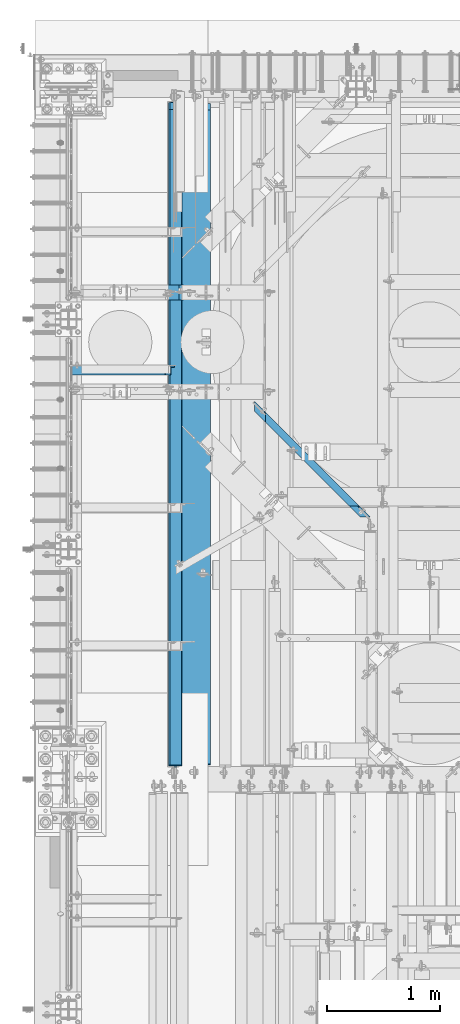
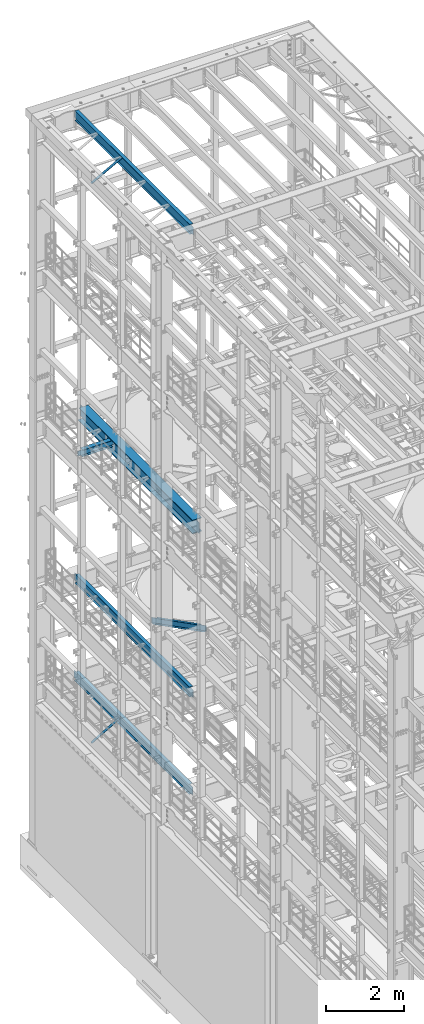
# One storey, part 1050 of 1876: 6 beams, 2 members, 8 elements without a shape of their own.
"""IFC2X3 building model written with IfcOpenShell, lengths in millimetres."""

from ifc_helpers import new_model, si_unit, frame, origin_with_axes, place, context, subcontext, project, spatial, faceted_brep, material, type_object, element, aggregate, save


model = new_model("IFC2X3")

# Units and contexts
model_context = context("Model", 3, precision=1e-05, world=origin_with_axes())
body_context = subcontext(model_context, "Body", "Model", "MODEL_VIEW")
ifc_project = project(units=[si_unit("LENGTHUNIT", "METRE", prefix="MILLI"), si_unit("AREAUNIT", "SQUARE_METRE"), si_unit("VOLUMEUNIT", "CUBIC_METRE"), si_unit("MASSUNIT", "GRAM", prefix="KILO"), si_unit("TIMEUNIT", "SECOND"), si_unit("PLANEANGLEUNIT", "RADIAN"), si_unit("SOLIDANGLEUNIT", "STERADIAN"), si_unit("THERMODYNAMICTEMPERATUREUNIT", "DEGREE_CELSIUS"), si_unit("LUMINOUSINTENSITYUNIT", "LUMEN")], contexts=[model_context])

# Site, building, storey
site_placement = place(None, origin_with_axes())
site = spatial("IfcSite", under=ifc_project, at=site_placement, CompositionType="ELEMENT")
building_placement = place(site_placement, origin_with_axes())
building = spatial("IfcBuilding", under=site, at=building_placement, Name="Undefined", CompositionType="ELEMENT")
storey_placement = place(building_placement, origin_with_axes())
storey = spatial("IfcBuildingStorey", under=building, at=storey_placement, Name="Undefined", CompositionType="ELEMENT", Elevation=0.0)

# Assembly, member
assembly_1_placement = place(storey_placement, origin_with_axes())
assembly_1 = element("IfcElementAssembly", 1, at=assembly_1_placement, inside=storey, AssemblyPlace="NOTDEFINED", PredefinedType="RIGID_FRAME")
ifc_material_1 = material(Name="STEEL/A36")
member_type = type_object("IfcMemberType", Name="L3X3X3/8", PredefinedType="NOTDEFINED")
member_1_placement = place(assembly_1_placement, frame((19.2391985516099, 11229.975, 4577.2144175513), z_axis=(0.0, -1.0, 0.0), x_axis=(0.863139327949449, 0.0, 0.50496584097043)))
member_1 = element("IfcMember", 2, at=member_1_placement, type_object=member_type, material=ifc_material_1, ObjectType="L3X3X3/8", context=body_context, shape_type="Brep", body=[
    faceted_brep([(22.9902048797903, -38.0999999999885, -38.1000000000004), (22.9902048797903, -38.0999999999885, -28.5750000000007), (22.9902048798026, 28.5750000000021, -28.5750000000007), (22.9902048798026, 28.5750000000021, 38.1000000000004), (22.990204879804, 38.0999999999999, 38.1000000000004), (22.990204879804, 38.0999999999999, -38.1000000000004), (987.145928714758, 28.5750000002508, 38.1000000000004), (987.145928714761, 38.10000000025, 38.1000000000004), (987.145928714761, 38.10000000025, -38.1000000000004), (987.145928714736, -38.0999999997393, -38.1000000000004), (987.145928714736, -38.0999999997393, -28.5750000000007), (987.145928714758, 28.5750000002508, -28.5750000000007)], [[[0, 1, 2, 3, 4, 5]], [[4, 3, 6, 7]], [[5, 4, 7, 8]], [[0, 5, 8, 9]], [[1, 0, 9, 10]], [[2, 1, 10, 11]], [[3, 2, 11, 6]], [[10, 9, 8, 7, 6, 11]]]),
])
aggregate(assembly_1, [member_1])

assembly_2_placement = place(storey_placement, origin_with_axes())
assembly_2 = element("IfcElementAssembly", 3, at=assembly_2_placement, inside=storey, AssemblyPlace="NOTDEFINED", PredefinedType="RIGID_FRAME")
member_2_placement = place(assembly_2_placement, frame((18.2754879686868, 11229.975, 22001.0692535961), z_axis=(0.0, -1.0, 0.0), x_axis=(0.877448093107104, 0.0, 0.479671600058526)))
member_2 = element("IfcMember", 4, at=member_2_placement, type_object=member_type, material=ifc_material_1, ObjectType="L3X3X3/8", context=body_context, shape_type="Brep", body=[
    faceted_brep([(22.6152978728696, 38.0999999999985, -38.0999999999999), (22.6152978728696, 38.0999999999985, 38.0999999999999), (1025.78606203808, 38.1000000013628, 38.0999999999999), (1025.78606203808, 38.1000000013628, -38.0999999999999), (22.6152978728605, 28.5750000000044, 38.0999999999999), (1025.78606203807, 28.5750000013722, 38.0999999999999), (22.6152978728605, 28.5750000000044, -28.5749999999998), (1025.78606203807, 28.5750000013722, -28.5749999999998), (22.6152978728023, -38.0999999999367, -28.5749999999998), (1025.78606203801, -38.0999999985652, -28.5749999999998), (22.6152978728023, -38.0999999999367, -38.0999999999999), (1025.78606203801, -38.0999999985652, -38.0999999999999)], [[[0, 1, 2, 3]], [[1, 4, 5, 2]], [[4, 6, 7, 5]], [[6, 8, 9, 7]], [[8, 10, 11, 9]], [[10, 0, 3, 11]], [[5, 7, 9, 11, 3, 2]], [[10, 8, 6, 4, 1, 0]]]),
])
aggregate(assembly_2, [member_2])

# Assembly, beam
assembly_3_placement = place(storey_placement, origin_with_axes())
assembly_3 = element("IfcElementAssembly", 5, at=assembly_3_placement, inside=storey, Name="BEAM", AssemblyPlace="NOTDEFINED", PredefinedType="RIGID_FRAME")
ifc_material_2 = material(Name="STEEL/A992")
beam_type_1 = type_object("IfcBeamType", Name="W12X16", PredefinedType="NOTDEFINED")
beam_1_placement = place(assembly_3_placement, frame((946.15, 7620.0, 8001.0), z_axis=(0.0, 0.0, 1.0), x_axis=(0.0, 1.0, 0.0)))
beam_1 = element("IfcBeam", 6, at=beam_1_placement, type_object=beam_type_1, material=ifc_material_2, Name="BEAM", ObjectType="W12X16", context=body_context, shape_type="Brep", body=[
    faceted_brep([(19.84375, -3.17499999999995, -126.999999999996), (19.84375, 3.17499999999995, -126.999999999996), (102.393750190735, 3.17500000000018, -127.000000000001), (102.393750190735, -3.17500000000018, -127.000000000001), (107.25382970878, 3.17500000000018, -127.966729922588), (107.25382970878, -3.17500000000018, -127.966729922588), (111.374006176934, 3.17500000000018, -130.719743823067), (111.374006176934, -3.17500000000018, -130.719743823067), (114.127020077412, 3.17500000000018, -134.839920291221), (114.127020077412, -3.17500000000018, -134.839920291221), (115.09375, -3.17500000000018, -139.699999809266), (115.09375, 3.17500000000018, -139.699999809266), (115.09375, 3.17500000000018, -146.05), (115.09375, 50.8000000000002, -146.05), (115.09375, 50.8000000000002, -152.4), (115.09375, -50.8000000000002, -152.4), (115.09375, -50.8000000000002, -146.05), (115.09375, -3.17500000000018, -146.05), (5914.23125, 50.8, 146.05), (5914.23125, 3.17500000000018, 146.05), (127.79375, 3.17500000000018, 146.05), (127.79375, 50.8000000000002, 146.05), (115.093750190735, -3.17500000000018, 114.299999999999), (115.093750190735, 3.17500000000018, 114.299999999999), (19.84375, 3.17500000000018, 114.299999999999), (19.84375, -3.17500000000018, 114.299999999999), (119.95382970878, -3.17500000000018, 115.266729922587), (119.95382970878, 3.17500000000018, 115.266729922587), (124.074006176934, -3.17500000000018, 118.019743823065), (124.074006176934, 3.17500000000018, 118.019743823065), (126.827020077412, -3.17500000000018, 122.139920291219), (126.827020077412, 3.17500000000018, 122.139920291219), (127.79375, -3.17500000000018, 126.999999809264), (127.79375, 3.17500000000018, 126.999999809264), (5914.23125, -50.8, 152.4), (5914.23125, 50.8, 152.4), (127.79375, 50.8000000000002, 152.4), (127.79375, -50.8000000000002, 152.4), (5914.23125, -50.8, 146.05), (127.79375, -50.8000000000002, 146.05), (5914.23125, -3.17500000000018, 146.05), (127.79375, -3.17500000000018, 146.05), (5914.23125, -3.17499999999995, 114.299999809266), (5914.23125, 3.17499999999995, 114.299999809266), (5915.19797992259, -3.17499999999995, 109.43992029122), (5915.19797992259, 3.17499999999995, 109.43992029122), (5917.95099382307, -3.17499999999995, 105.319743823066), (5917.95099382307, 3.17499999999995, 105.319743823066), (5922.07117029122, -3.17499999999995, 102.566729922588), (5922.07117029122, 3.17499999999995, 102.566729922588), (5926.93124980926, -3.17499999999995, 101.6), (5926.93124980926, 3.17499999999995, 101.6), (6072.98125, -3.17499999999995, 101.6), (6072.98125, 3.17499999999995, 101.6), (6072.98125, -3.17499999999995, -127.0), (6072.98125, 3.17499999999995, -127.0), (5990.43124980926, -3.17499999999995, -127.0), (5990.43124980926, 3.17499999999995, -127.0), (5985.57117029122, -3.17499999999995, -127.966729922588), (5985.57117029122, 3.17499999999995, -127.966729922588), (5981.45099382307, -3.17499999999995, -130.719743823066), (5981.45099382307, 3.17499999999995, -130.719743823066), (5978.69797992259, -3.17499999999995, -134.83992029122), (5978.69797992259, 3.17499999999995, -134.83992029122), (5977.73125, -3.17499999999995, -139.699999809265), (5977.73125, 3.17499999999995, -139.699999809265), (5977.73125, -3.17500000000018, -146.05), (5977.73125, -50.8, -146.05), (5977.73125, -50.8, -152.4), (5977.73125, 50.8, -152.4), (5977.73125, 50.8, -146.05), (5977.73125, 3.17500000000018, -146.05)], [[[0, 1, 2, 3]], [[3, 2, 4, 5]], [[5, 4, 6, 7]], [[7, 6, 8, 9]], [[10, 11, 12, 13, 14, 15, 16, 17]], [[9, 8, 11, 10]], [[18, 19, 20, 21]], [[22, 23, 24, 25]], [[26, 27, 23, 22]], [[28, 29, 27, 26]], [[30, 31, 29, 28]], [[32, 33, 31, 30]], [[34, 35, 36, 37]], [[38, 34, 37, 39]], [[40, 38, 39, 41]], [[37, 36, 21, 20, 33, 32, 41, 39]], [[35, 18, 21, 36]], [[34, 38, 40, 42, 43, 19, 18, 35]], [[44, 45, 43, 42]], [[46, 47, 45, 44]], [[48, 49, 47, 46]], [[50, 51, 49, 48]], [[52, 53, 51, 50]], [[53, 52, 54, 55]], [[54, 56, 57, 55]], [[58, 59, 57, 56]], [[60, 61, 59, 58]], [[62, 63, 61, 60]], [[64, 65, 63, 62]], [[66, 67, 68, 69, 70, 71, 65, 64]], [[67, 66, 17, 16]], [[68, 67, 16, 15]], [[69, 68, 15, 14]], [[70, 69, 14, 13]], [[71, 70, 13, 12]], [[6, 4, 2, 1, 24, 23, 27, 29, 31, 33, 20, 19, 43, 45, 47, 49, 51, 53, 55, 57, 59, 61, 63, 65, 71, 12, 11, 8]], [[25, 24, 1, 0]], [[66, 64, 62, 60, 58, 56, 54, 52, 50, 48, 46, 44, 42, 40, 41, 32, 30, 28, 26, 22, 25, 0, 3, 5, 7, 9, 10, 17]]]),
])
aggregate(assembly_3, [beam_1])

assembly_4_placement = place(storey_placement, origin_with_axes())
assembly_4 = element("IfcElementAssembly", 7, at=assembly_4_placement, inside=storey, Name="BEAM", AssemblyPlace="NOTDEFINED", PredefinedType="RIGID_FRAME")
beam_2_placement = place(assembly_4_placement, frame((952.5, 7620.0, 22402.8), z_axis=(0.0, 0.0, 1.0), x_axis=(0.0, 1.0, 0.0)))
beam_2 = element("IfcBeam", 8, at=beam_2_placement, type_object=beam_type_1, material=ifc_material_2, Name="BEAM", ObjectType="W12X16", context=body_context, shape_type="Brep", body=[
    faceted_brep([(19.84375, -3.17499999999995, -126.999999999996), (19.84375, 3.17499999999995, -126.999999999996), (102.393750190735, 3.17500000000018, -127.000000000001), (102.393750190735, -3.17500000000018, -127.000000000001), (107.25382970878, 3.17500000000018, -127.966729922588), (107.25382970878, -3.17500000000018, -127.966729922588), (111.374006176934, 3.17500000000018, -130.719743823067), (111.374006176934, -3.17500000000018, -130.719743823067), (114.127020077412, 3.17500000000018, -134.839920291221), (114.127020077412, -3.17500000000018, -134.839920291221), (115.09375, -3.17500000000018, -139.699999809266), (115.09375, 3.17500000000018, -139.699999809266), (115.09375, 3.17500000000018, -146.05), (115.09375, 50.8000000000002, -146.05), (115.09375, 50.8000000000002, -152.4), (115.09375, -50.8000000000002, -152.4), (115.09375, -50.8000000000002, -146.05), (115.09375, -3.17500000000018, -146.05), (127.79375, 3.17500000000018, 146.05), (127.79375, 50.8000000000002, 146.05), (5968.20625, 50.8, 146.05), (5968.20625, 3.17499999999995, 146.05), (115.093750190735, -3.17500000000018, 114.299999999999), (115.093750190735, 3.17500000000018, 114.299999999999), (19.84375, 3.17500000000018, 114.299999999999), (19.84375, -3.17500000000018, 114.299999999999), (119.95382970878, -3.17500000000018, 115.266729922587), (119.95382970878, 3.17500000000018, 115.266729922587), (124.074006176934, -3.17500000000018, 118.019743823065), (124.074006176934, 3.17500000000018, 118.019743823065), (126.827020077412, -3.17500000000018, 122.139920291219), (126.827020077412, 3.17500000000018, 122.139920291219), (127.79375, -3.17500000000018, 126.999999809264), (127.79375, 3.17500000000018, 126.999999809264), (127.79375, 50.8000000000002, 152.4), (127.79375, -50.8000000000002, 152.4), (5968.20625, -50.8, 152.4), (5968.20625, 50.8, 152.4), (127.79375, -50.8000000000002, 146.05), (5968.20625, -50.8, 146.05), (127.79375, -3.17500000000018, 146.05), (5968.20625, -3.17499999999995, 146.05), (5968.20625, -3.17499999999995, 126.999999809264), (5968.20625, 3.17499999999995, 126.999999809264), (5969.17297992259, -3.17499999999995, 122.139920291219), (5969.17297992259, 3.17499999999995, 122.139920291219), (5971.92599382307, -3.17499999999995, 118.019743823065), (5971.92599382307, 3.17499999999995, 118.019743823065), (5976.04617029122, -3.17499999999995, 115.266729922587), (5976.04617029122, 3.17499999999995, 115.266729922587), (5980.90624980927, -3.17499999999995, 114.299999999999), (5980.90624980927, 3.17499999999995, 114.299999999999), (6076.15625, -3.17499999999995, 114.299999999999), (6076.15625, 3.17499999999995, 114.299999999999), (6076.15625, -3.17499999999995, -126.999999999996), (6076.15625, 3.17499999999995, -126.999999999996), (5993.60624980927, -3.17499999999995, -127.000000000001), (5993.60624980927, 3.17499999999995, -127.000000000001), (5988.74617029122, -3.17499999999995, -127.966729922588), (5988.74617029122, 3.17499999999995, -127.966729922588), (5984.62599382307, -3.17499999999995, -130.719743823067), (5984.62599382307, 3.17499999999995, -130.719743823067), (5981.87297992259, -3.17499999999995, -134.839920291221), (5981.87297992259, 3.17499999999995, -134.839920291221), (5980.90625, -3.17499999999995, -139.699999809266), (5980.90625, 3.17499999999995, -139.699999809266), (5980.90625, -3.17499999999995, -146.05), (5980.90625, -50.8, -146.05), (5980.90625, -50.8, -152.4), (5980.90625, 50.8, -152.4), (5980.90625, 50.8, -146.05), (5980.90625, 3.17499999999995, -146.05)], [[[0, 1, 2, 3]], [[3, 2, 4, 5]], [[5, 4, 6, 7]], [[7, 6, 8, 9]], [[10, 11, 12, 13, 14, 15, 16, 17]], [[9, 8, 11, 10]], [[18, 19, 20, 21]], [[22, 23, 24, 25]], [[26, 27, 23, 22]], [[28, 29, 27, 26]], [[30, 31, 29, 28]], [[32, 33, 31, 30]], [[34, 35, 36, 37]], [[35, 38, 39, 36]], [[38, 40, 41, 39]], [[35, 34, 19, 18, 33, 32, 40, 38]], [[19, 34, 37, 20]], [[36, 39, 41, 42, 43, 21, 20, 37]], [[44, 45, 43, 42]], [[46, 47, 45, 44]], [[48, 49, 47, 46]], [[50, 51, 49, 48]], [[52, 53, 51, 50]], [[53, 52, 54, 55]], [[54, 56, 57, 55]], [[58, 59, 57, 56]], [[60, 61, 59, 58]], [[62, 63, 61, 60]], [[64, 65, 63, 62]], [[66, 67, 68, 69, 70, 71, 65, 64]], [[17, 16, 67, 66]], [[16, 15, 68, 67]], [[15, 14, 69, 68]], [[14, 13, 70, 69]], [[13, 12, 71, 70]], [[59, 61, 63, 65, 71, 12, 11, 8, 6, 4, 2, 1, 24, 23, 27, 29, 31, 33, 18, 21, 43, 45, 47, 49, 51, 53, 55, 57]], [[25, 24, 1, 0]], [[52, 50, 48, 46, 44, 42, 41, 40, 32, 30, 28, 26, 22, 25, 0, 3, 5, 7, 9, 10, 17, 66, 64, 62, 60, 58, 56, 54]]]),
])
aggregate(assembly_4, [beam_2])

assembly_5_placement = place(storey_placement, origin_with_axes())
assembly_5 = element("IfcElementAssembly", 9, at=assembly_5_placement, inside=storey, Name="BEAM", AssemblyPlace="NOTDEFINED", PredefinedType="RIGID_FRAME")
beam_3_placement = place(assembly_5_placement, frame((933.45, 7620.0, 4978.4), z_axis=(0.0, 0.0, 1.0), x_axis=(0.0, 1.0, 0.0)))
beam_3 = element("IfcBeam", 10, at=beam_3_placement, type_object=beam_type_1, material=ifc_material_2, Name="BEAM", ObjectType="W12X16", context=body_context, shape_type="Brep", body=[
    faceted_brep([(19.84375, -3.17499999999995, -126.999999999996), (19.84375, 3.17499999999995, -126.999999999996), (102.393750190735, 3.17500000000018, -127.000000000001), (102.393750190735, -3.17500000000018, -127.000000000001), (107.25382970878, 3.17500000000018, -127.966729922588), (107.25382970878, -3.17500000000018, -127.966729922588), (111.374006176934, 3.17500000000018, -130.719743823067), (111.374006176934, -3.17500000000018, -130.719743823067), (114.127020077412, 3.17500000000018, -134.839920291221), (114.127020077412, -3.17500000000018, -134.839920291221), (115.09375, -3.17500000000018, -139.699999809266), (115.09375, 3.17500000000018, -139.699999809266), (115.09375, 3.17500000000018, -146.05), (115.09375, 50.8000000000002, -146.05), (115.09375, 50.8000000000002, -152.4), (115.09375, -50.8000000000002, -152.4), (115.09375, -50.8000000000002, -146.05), (115.09375, -3.17500000000018, -146.05), (5914.23125, 50.8, 146.05), (5914.23125, 3.17500000000018, 146.05), (127.79375, 3.17500000000018, 146.05), (127.79375, 50.8000000000002, 146.05), (115.093750190735, -3.17500000000018, 114.299999999999), (115.093750190735, 3.17500000000018, 114.299999999999), (19.84375, 3.17500000000018, 114.299999999999), (19.84375, -3.17500000000018, 114.299999999999), (119.95382970878, -3.17500000000018, 115.266729922587), (119.95382970878, 3.17500000000018, 115.266729922587), (124.074006176934, -3.17500000000018, 118.019743823065), (124.074006176934, 3.17500000000018, 118.019743823065), (126.827020077412, -3.17500000000018, 122.139920291219), (126.827020077412, 3.17500000000018, 122.139920291219), (127.79375, -3.17500000000018, 126.999999809264), (127.79375, 3.17500000000018, 126.999999809264), (5914.23125, -50.8, 152.4), (5914.23125, 50.8, 152.4), (127.79375, 50.8000000000002, 152.4), (127.79375, -50.8000000000002, 152.4), (5914.23125, -50.8, 146.05), (127.79375, -50.8000000000002, 146.05), (5914.23125, -3.17500000000018, 146.05), (127.79375, -3.17500000000018, 146.05), (5914.23125, -3.17499999999995, 114.299999809266), (5914.23125, 3.17499999999995, 114.299999809266), (5915.19797992259, -3.17499999999995, 109.43992029122), (5915.19797992259, 3.17499999999995, 109.43992029122), (5917.95099382307, -3.17499999999995, 105.319743823066), (5917.95099382307, 3.17499999999995, 105.319743823066), (5922.07117029122, -3.17499999999995, 102.566729922588), (5922.07117029122, 3.17499999999995, 102.566729922588), (5926.93124980926, -3.17499999999995, 101.6), (5926.93124980926, 3.17499999999995, 101.6), (6072.98125, -3.17499999999995, 101.6), (6072.98125, 3.17499999999995, 101.6), (6072.98125, -3.17499999999995, -127.0), (6072.98125, 3.17499999999995, -127.0), (5990.43124980926, -3.17499999999995, -127.0), (5990.43124980926, 3.17499999999995, -127.0), (5985.57117029122, -3.17499999999995, -127.966729922588), (5985.57117029122, 3.17499999999995, -127.966729922588), (5981.45099382307, -3.17499999999995, -130.719743823066), (5981.45099382307, 3.17499999999995, -130.719743823066), (5978.69797992259, -3.17499999999995, -134.83992029122), (5978.69797992259, 3.17499999999995, -134.83992029122), (5977.73125, -3.17499999999995, -139.699999809265), (5977.73125, 3.17499999999995, -139.699999809265), (5977.73125, -3.17500000000018, -146.05), (5977.73125, -50.8, -146.05), (5977.73125, -50.8, -152.4), (5977.73125, 50.8, -152.4), (5977.73125, 50.8, -146.05), (5977.73125, 3.17500000000018, -146.05)], [[[0, 1, 2, 3]], [[3, 2, 4, 5]], [[5, 4, 6, 7]], [[7, 6, 8, 9]], [[10, 11, 12, 13, 14, 15, 16, 17]], [[9, 8, 11, 10]], [[18, 19, 20, 21]], [[22, 23, 24, 25]], [[26, 27, 23, 22]], [[28, 29, 27, 26]], [[30, 31, 29, 28]], [[32, 33, 31, 30]], [[34, 35, 36, 37]], [[38, 34, 37, 39]], [[40, 38, 39, 41]], [[37, 36, 21, 20, 33, 32, 41, 39]], [[35, 18, 21, 36]], [[34, 38, 40, 42, 43, 19, 18, 35]], [[44, 45, 43, 42]], [[46, 47, 45, 44]], [[48, 49, 47, 46]], [[50, 51, 49, 48]], [[52, 53, 51, 50]], [[53, 52, 54, 55]], [[54, 56, 57, 55]], [[58, 59, 57, 56]], [[60, 61, 59, 58]], [[62, 63, 61, 60]], [[64, 65, 63, 62]], [[66, 67, 68, 69, 70, 71, 65, 64]], [[67, 66, 17, 16]], [[68, 67, 16, 15]], [[69, 68, 15, 14]], [[70, 69, 14, 13]], [[71, 70, 13, 12]], [[6, 4, 2, 1, 24, 23, 27, 29, 31, 33, 20, 19, 43, 45, 47, 49, 51, 53, 55, 57, 59, 61, 63, 65, 71, 12, 11, 8]], [[25, 24, 1, 0]], [[66, 64, 62, 60, 58, 56, 54, 52, 50, 48, 46, 44, 42, 40, 41, 32, 30, 28, 26, 22, 25, 0, 3, 5, 7, 9, 10, 17]]]),
])
aggregate(assembly_5, [beam_3])

assembly_6_placement = place(storey_placement, origin_with_axes())
assembly_6 = element("IfcElementAssembly", 11, at=assembly_6_placement, inside=storey, Name="BEAM", AssemblyPlace="NOTDEFINED", PredefinedType="RIGID_FRAME")
beam_type_2 = type_object("IfcBeamType", Name="W8X18", PredefinedType="NOTDEFINED")
beam_4_placement = place(assembly_6_placement, frame((-2.8421709430404e-13, 11918.95, 13206.4125), z_axis=(0.0, 0.0, 1.0), x_axis=(1.0, 0.0, 0.0)))
beam_4 = element("IfcBeam", 12, at=beam_4_placement, type_object=beam_type_2, material=ifc_material_2, Name="BEAM", ObjectType="W8X18", context=body_context, shape_type="Brep", body=[
    faceted_brep([(19.8437500000002, -3.17500000000018, -77.7874999999985), (19.8437500000002, 3.17500000000018, -77.7874999999985), (96.043750190735, 3.17499999999927, -77.7875000000004), (96.043750190735, -3.17499999999927, -77.7875000000004), (100.903829708781, 3.17499999999927, -78.7542299225879), (100.903829708781, -3.17499999999927, -78.7542299225879), (105.024006176934, 3.17499999999927, -81.5072438230654), (105.024006176934, -3.17499999999927, -81.5072438230654), (107.777020077412, 3.17499999999927, -85.6274202912191), (107.777020077412, -3.17499999999927, -85.6274202912191), (108.74375, -3.17499999999927, -90.4874998092655), (108.74375, 3.17499999999927, -90.4874998092655), (108.74375, 3.17499999999927, -95.25), (108.74375, 66.6749999999993, -95.25), (108.74375, 66.6750000000002, -103.1875), (108.74375, -66.6750000000002, -103.1875), (108.74375, -66.6749999999993, -95.25), (108.74375, -3.17499999999927, -95.25), (127.79375, 3.17499999999927, 95.25), (127.79375, 66.6749999999993, 95.25), (977.900004800633, 66.6749999999993, 95.25), (977.900004800633, 3.17499999999927, 95.25), (115.093750190735, -3.17499999999927, 71.4375), (115.093750190735, 3.17499999999927, 71.4375), (19.8437499999999, 3.17499999999927, 71.4375), (19.8437499999999, -3.17499999999927, 71.4375), (119.953829708781, -3.17499999999927, 72.4042299225875), (119.953829708781, 3.17499999999927, 72.4042299225875), (124.074006176934, -3.17499999999927, 75.1572438230651), (124.074006176934, 3.17499999999927, 75.1572438230651), (126.827020077412, -3.17499999999927, 79.2774202912187), (126.827020077412, 3.17499999999927, 79.2774202912187), (127.79375, -3.17499999999927, 84.1374998092651), (127.79375, 3.17499999999927, 84.1374998092651), (127.79375, -66.6749999999993, 103.1875), (127.79375, 66.6749999999993, 103.1875), (127.79375, -3.17499999999927, 95.25), (127.79375, -66.6749999999993, 95.25), (977.900004800633, -3.17499999999927, 95.25), (977.900004800633, -66.6749999999993, 95.25), (977.900004800633, -66.6749999999993, 103.1875), (977.900004800633, 66.6749999999993, 103.1875), (977.900004800633, -3.17499999999927, 84.1374998092651), (977.900004800633, 3.17499999999927, 84.1374998092651), (978.866734723221, -3.17499999999927, 79.2774202912187), (978.866734723221, 3.17499999999927, 79.2774202912187), (981.619748623699, -3.17499999999927, 75.1572438230651), (981.619748623699, 3.17499999999927, 75.1572438230651), (985.739925091853, -3.17499999999927, 72.4042299225875), (985.739925091853, 3.17499999999927, 72.4042299225875), (990.600004609898, -3.17499999999927, 71.4375), (990.600004609898, 3.17499999999927, 71.4375), (1104.90000480063, -3.17499999999927, 71.4375), (1104.90000480063, 3.17499999999927, 71.4375), (1104.90000480063, -3.17499999999927, -77.7875000000004), (1104.90000480063, 3.17499999999927, -77.7875000000004), (1028.7000046099, -3.17499999999927, -77.7875000000004), (1028.7000046099, 3.17499999999927, -77.7875000000004), (1023.83992509185, -3.17499999999927, -78.7542299225879), (1023.83992509185, 3.17499999999927, -78.7542299225879), (1019.7197486237, -3.17499999999927, -81.5072438230654), (1019.7197486237, 3.17499999999927, -81.5072438230654), (1016.96673472322, -3.17499999999927, -85.6274202912191), (1016.96673472322, 3.17499999999927, -85.6274202912191), (1016.00000480063, -3.17499999999927, -90.4874998092655), (1016.00000480063, 3.17499999999927, -90.4874998092655), (1016.00000480063, -3.17499999999927, -95.25), (1016.00000480063, -66.6749999999993, -95.25), (1016.00000480063, -66.6749999999993, -103.1875), (1016.00000480063, 66.6749999999993, -103.1875), (1016.00000480063, 66.6749999999993, -95.25), (1016.00000480063, 3.17499999999927, -95.25)], [[[0, 1, 2, 3]], [[3, 2, 4, 5]], [[5, 4, 6, 7]], [[7, 6, 8, 9]], [[10, 11, 12, 13, 14, 15, 16, 17]], [[9, 8, 11, 10]], [[18, 19, 20, 21]], [[22, 23, 24, 25]], [[26, 27, 23, 22]], [[28, 29, 27, 26]], [[30, 31, 29, 28]], [[32, 33, 31, 30]], [[34, 35, 19, 18, 33, 32, 36, 37]], [[37, 36, 38, 39]], [[34, 37, 39, 40]], [[35, 34, 40, 41]], [[19, 35, 41, 20]], [[40, 39, 38, 42, 43, 21, 20, 41]], [[44, 45, 43, 42]], [[46, 47, 45, 44]], [[48, 49, 47, 46]], [[50, 51, 49, 48]], [[52, 53, 51, 50]], [[53, 52, 54, 55]], [[54, 56, 57, 55]], [[58, 59, 57, 56]], [[60, 61, 59, 58]], [[62, 63, 61, 60]], [[64, 65, 63, 62]], [[66, 67, 68, 69, 70, 71, 65, 64]], [[67, 66, 17, 16]], [[68, 67, 16, 15]], [[69, 68, 15, 14]], [[70, 69, 14, 13]], [[71, 70, 13, 12]], [[6, 4, 2, 1, 24, 23, 27, 29, 31, 33, 18, 21, 43, 45, 47, 49, 51, 53, 55, 57, 59, 61, 63, 65, 71, 12, 11, 8]], [[25, 24, 1, 0]], [[66, 64, 62, 60, 58, 56, 54, 52, 50, 48, 46, 44, 42, 38, 36, 32, 30, 28, 26, 22, 25, 0, 3, 5, 7, 9, 10, 17]]]),
])
aggregate(assembly_6, [beam_4])

assembly_7_placement = place(storey_placement, origin_with_axes())
assembly_7 = element("IfcElementAssembly", 13, at=assembly_7_placement, inside=storey, Name="BEAM", AssemblyPlace="NOTDEFINED", PredefinedType="RIGID_FRAME")
beam_type_3 = type_object("IfcBeamType", Name="C8X18.75", PredefinedType="NOTDEFINED")
beam_5_placement = place(assembly_7_placement, frame((1391.22507232719, 11166.1192503376, 8051.8), z_axis=(0.0, 0.0, 1.0), x_axis=(0.707305809668414, -0.706907696668602, 0.0)))
beam_5 = element("IfcBeam", 14, at=beam_5_placement, type_object=beam_type_3, material=ifc_material_1, Name="BEAM", ObjectType="C8X18.75", context=body_context, shape_type="Brep", body=[
    faceted_brep([(386.661601394823, -31.7500000001164, -101.6), (323.197342901677, 31.7499999999054, -101.6), (1772.80211504471, 31.7499999994725, -101.6), (1709.26635340903, -31.7500000005111, -101.6), (386.661601394823, -31.7500000001164, -97.3645500000002), (1709.26635340903, -31.7500000005111, -97.3645500000002), (335.890194600306, 19.049999999901, -88.9012700000003), (1760.09496271758, 19.0499999994754, -88.9012700000003), (335.890194600306, 19.049999999901, 73.0249999999996), (323.197342901677, 31.7499999999054, 73.0249999999996), (455.967320369644, 19.0499999998647, 73.0249999999996), (443.274468671014, 31.749999999869, 73.0249999999996), (462.838576694156, 19.0499999998628, 73.9917299225872), (450.145724995527, 31.7499999998672, 73.9917299225872), (468.663746531355, 19.049999999861, 76.7447438230656), (455.970894832727, 31.7499999998672, 76.7447438230656), (472.556000578824, 19.049999999861, 80.8649202912193), (459.863148880195, 31.7499999998654, 80.8649202912193), (473.922778441206, 19.0499999998592, 85.7249998092648), (461.229926742577, 31.7499999998654, 85.7249998092648), (524.694185235578, -31.7500000001583, 101.6), (461.229926742471, 31.7499999998654, 101.6), (473.922778441093, 19.049999999861, 88.9012700000003), (524.694185235578, -31.7500000001583, 97.3645500000002), (1621.98464234188, 19.0499999995172, 88.9012700000003), (1571.15603303337, -31.7500000004693, 97.3645500000002), (1571.15603303337, -31.7500000004693, 101.6), (1634.691794669, 31.7499999995143, 101.6), (1634.69179466905, 31.7499999995143, 85.7249998092657), (1636.05934226705, 31.7499999995125, 80.8649202912202), (1639.95378833611, 31.7499999995125, 76.7447438230665), (1645.78223876546, 31.7499999995107, 73.9917299225881), (1652.65736481226, 31.7499999995089, 73.0250000000005), (1772.80211504471, 31.7499999994725, 73.0250000000005), (1760.09496271758, 19.0499999994754, 73.0250000000005), (1633.07508643833, 19.0499999995136, 73.9917299225881), (1627.24663600898, 19.0499999995154, 76.7447438230665), (1623.35218993992, 19.0499999995172, 80.8649202912202), (1621.98464234191, 19.0499999995172, 85.7249998092657), (1639.95021248512, 19.0499999995118, 73.0250000000005)], [[[0, 1, 2, 3]], [[4, 0, 3, 5]], [[6, 4, 5, 7]], [[1, 0, 4, 6, 8, 9]], [[10, 11, 9, 8]], [[12, 13, 11, 10]], [[14, 15, 13, 12]], [[16, 17, 15, 14]], [[18, 19, 17, 16]], [[20, 21, 19, 18, 22, 23]], [[23, 22, 24, 25]], [[20, 23, 25, 26]], [[21, 20, 26, 27]], [[2, 1, 9, 11, 13, 15, 17, 19, 21, 27, 28, 29, 30, 31, 32, 33]], [[7, 5, 3, 2, 33, 34]], [[35, 36, 37, 38, 24, 22, 18, 16, 14, 12, 10, 8, 6, 7, 34, 39]], [[33, 32, 39, 34]], [[31, 35, 39, 32]], [[30, 36, 35, 31]], [[29, 37, 36, 30]], [[28, 38, 37, 29]], [[27, 26, 25, 24, 38, 28]]]),
])
aggregate(assembly_7, [beam_5])

assembly_8_placement = place(storey_placement, origin_with_axes())
assembly_8 = element("IfcElementAssembly", 15, at=assembly_8_placement, inside=storey, Name="BEAM", AssemblyPlace="NOTDEFINED", PredefinedType="RIGID_FRAME")
beam_type_4 = type_object("IfcBeamType", Name="W16X89", PredefinedType="NOTDEFINED")
beam_6_placement = place(assembly_8_placement, frame((1123.95000480063, 7619.97410311922, 13096.875), z_axis=(0.0, 0.0, 1.0), x_axis=(0.0, 1.0, 0.0)))
beam_6 = element("IfcBeam", 16, at=beam_6_placement, type_object=beam_type_4, material=ifc_material_2, Name="BEAM", ObjectType="W16X89", context=body_context, shape_type="Brep", body=[
    faceted_brep([(5967.43839688078, -6.34999999999991, -190.5), (5967.43839688078, -131.7625, -190.5), (5967.43839688078, -131.7625, -212.725), (5967.43839688078, 131.7625, -212.725), (5967.43839688078, 131.7625, -190.5), (5967.43839688078, 6.34999999999991, -190.5), (5967.43839688078, 6.34999999999991, -187.324999809263), (5967.43839688078, -6.34999999999991, -187.324999809263), (5968.40512680336, 6.34999999999991, -182.464920291217), (5968.40512680336, -6.34999999999991, -182.464920291217), (5971.15814070384, 6.34999999999991, -178.344743823063), (5971.15814070384, -6.34999999999991, -178.344743823063), (5975.27831717199, 6.34999999999991, -175.591729922586), (5975.27831717199, -6.34999999999991, -175.591729922586), (5980.13839669004, 6.34999999999991, -174.624999999998), (5980.13839669004, -6.34999999999991, -174.624999999998), (6075.38839688078, -6.34999999999991, -174.624999999998), (6075.38839688078, 6.34999999999991, -174.624999999998), (134.169646880778, 6.34999999999991, 190.5), (134.169646880778, 131.7625, 190.5), (5910.28839688078, 131.7625, 190.5), (5910.28839688078, 6.34999999999991, 190.5), (127.819646880777, -6.34999999999991, -187.324999809265), (127.819646880777, 6.34999999999991, -187.324999809265), (127.819646880777, 6.34999999999991, -190.5), (127.819646880777, 131.7625, -190.5), (127.819646880777, 131.7625, -212.725), (127.819646880777, -131.7625, -212.725), (127.819646880777, -131.7625, -190.5), (127.819646880777, -6.34999999999991, -190.5), (126.85291695819, -6.34999999999991, -182.464920291219), (126.85291695819, 6.34999999999991, -182.464920291219), (124.099903057711, -6.34999999999991, -178.344743823065), (124.099903057711, 6.34999999999991, -178.344743823065), (119.979726589558, -6.34999999999991, -175.591729922588), (119.979726589558, 6.34999999999991, -175.591729922588), (115.119647071512, -6.34999999999991, -174.625), (115.119647071512, 6.34999999999991, -174.625), (19.8696468807775, -6.34999999999991, -174.625), (19.8696468807775, 6.34999999999991, -174.625), (19.8696468807775, -6.34999999999991, 168.275), (19.8696468807775, 6.34999999999991, 168.275), (121.469647071513, -6.34999999999991, 168.275), (121.469647071513, 6.34999999999991, 168.275), (126.329726589558, -6.34999999999991, 169.241729922587), (126.329726589558, 6.34999999999991, 169.241729922587), (130.449903057712, -6.34999999999991, 171.994743823065), (130.449903057712, 6.34999999999991, 171.994743823065), (133.20291695819, -6.34999999999991, 176.114920291218), (133.20291695819, 6.34999999999991, 176.114920291218), (134.169646880778, -6.34999999999991, 180.974999809265), (134.169646880778, 6.34999999999991, 180.974999809265), (134.169646880778, -131.7625, 212.725), (134.169646880778, 131.7625, 212.725), (134.169646880778, -6.34999999999991, 190.5), (134.169646880778, -131.7625, 190.5), (5910.28839688078, -6.34999999999991, 190.5), (5910.28839688078, -131.7625, 190.5), (5910.28839688078, -131.7625, 212.725), (5910.28839688078, 131.7625, 212.725), (5910.28839688078, -6.34999999999991, 180.974999809267), (5910.28839688078, 6.34999999999991, 180.974999809267), (5911.25512680336, -6.34999999999991, 176.11492029122), (5911.25512680336, 6.34999999999991, 176.11492029122), (5914.00814070384, -6.34999999999991, 171.994743823067), (5914.00814070384, 6.34999999999991, 171.994743823067), (5918.128317172, -6.34999999999991, 169.241729922589), (5918.128317172, 6.34999999999991, 169.241729922589), (5922.98839669004, -6.34999999999991, 168.275000000001), (5922.98839669004, 6.34999999999991, 168.275000000001), (6075.38839688078, -6.34999999999991, 168.275000000001), (6075.38839688078, 6.34999999999991, 168.275000000001)], [[[0, 1, 2, 3, 4, 5, 6, 7]], [[7, 6, 8, 9]], [[9, 8, 10, 11]], [[11, 10, 12, 13]], [[13, 12, 14, 15]], [[16, 15, 14, 17]], [[18, 19, 20, 21]], [[22, 23, 24, 25, 26, 27, 28, 29]], [[30, 31, 23, 22]], [[32, 33, 31, 30]], [[34, 35, 33, 32]], [[36, 37, 35, 34]], [[38, 39, 37, 36]], [[40, 41, 39, 38]], [[42, 43, 41, 40]], [[44, 45, 43, 42]], [[46, 47, 45, 44]], [[48, 49, 47, 46]], [[50, 51, 49, 48]], [[52, 53, 19, 18, 51, 50, 54, 55]], [[55, 54, 56, 57]], [[52, 55, 57, 58]], [[53, 52, 58, 59]], [[19, 53, 59, 20]], [[58, 57, 56, 60, 61, 21, 20, 59]], [[62, 63, 61, 60]], [[64, 65, 63, 62]], [[66, 67, 65, 64]], [[68, 69, 67, 66]], [[70, 71, 69, 68]], [[71, 70, 16, 17]], [[12, 10, 8, 6, 5, 24, 23, 31, 33, 35, 37, 39, 41, 43, 45, 47, 49, 51, 18, 21, 61, 63, 65, 67, 69, 71, 17, 14]], [[25, 24, 5, 4]], [[26, 25, 4, 3]], [[27, 26, 3, 2]], [[28, 27, 2, 1]], [[29, 28, 1, 0]], [[70, 68, 66, 64, 62, 60, 56, 54, 50, 48, 46, 44, 42, 40, 38, 36, 34, 32, 30, 22, 29, 0, 7, 9, 11, 13, 15, 16]]]),
])
aggregate(assembly_8, [beam_6])

save(model, "model.ifc")
